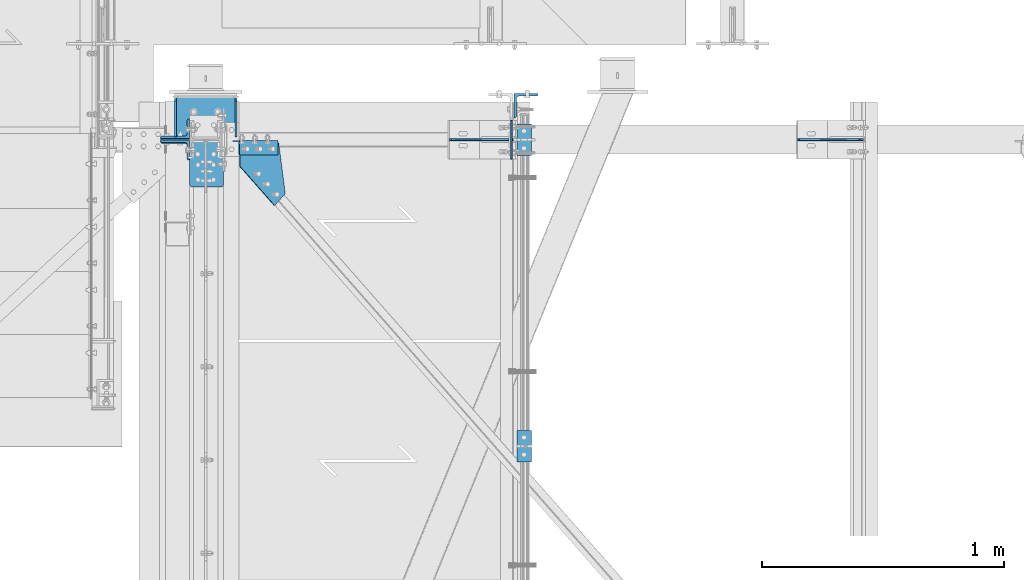
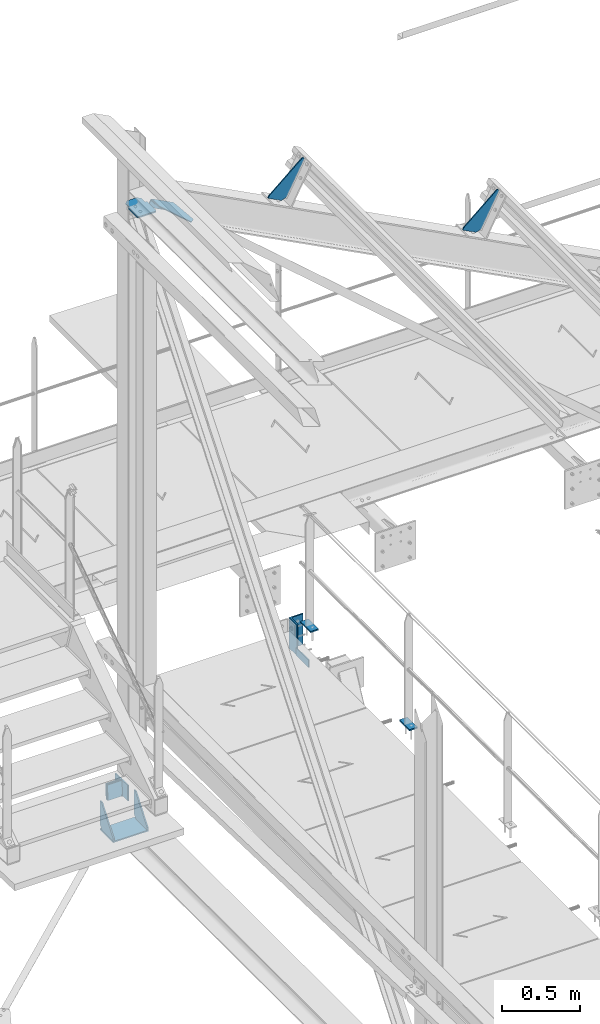
# One storey, part 83 of 496: 11 beams, 3 members, 11 elements without a shape of their own.
"""IFC2X3 building model written with IfcOpenShell, lengths in millimetres."""

import ifcopenshell
import ifcopenshell.guid

model = None  # the IFC model being written
_history = None  # IfcOwnerHistory: only IFC2X3 demands one
_inside = {}  # id of a spatial element -> (the spatial element, [elements in it])
_under = {}  # id of a project, library or spatial element -> (it, [spatial elements below it])
_declared = {}  # id of a project -> (the project, [libraries it declares])
_typed = {}  # id of a type object -> (the type object, [elements of that type])
_made_of = {}  # id of a material, layer set ... -> (it, [elements and type objects made of it])


def new_model(schema):
    """Start an empty IFC model of exactly this schema.

    Asked for "IFC4X3", IfcOpenShell would pick the latest addendum, in which some entities
    have other attributes; the version numbers below select the first issue.
    IFC2X3 requires an IfcOwnerHistory on every rooted entity: one is made here for all.
    """
    global model, _history
    if schema == "IFC4X3":
        model = ifcopenshell.file(schema_version=(4, 3, 0, 0))
    else:
        model = ifcopenshell.file(schema=schema)
    _inside.clear()
    _under.clear()
    _declared.clear()
    _typed.clear()
    _made_of.clear()
    _history = None
    if model.schema == "IFC2X3":
        org = make("IfcOrganization", Name="unknown")
        user = make(
            "IfcPersonAndOrganization",
            ThePerson=make("IfcPerson", FamilyName="unknown"),
            TheOrganization=org,
        )
        app = make(
            "IfcApplication",
            ApplicationDeveloper=org,
            Version="unknown",
            ApplicationFullName="unknown",
            ApplicationIdentifier="unknown",
        )
        _history = make(
            "IfcOwnerHistory",
            OwningUser=user,
            OwningApplication=app,
            ChangeAction="ADDED",
            CreationDate=0,
        )
    return model


def make(cls, **values):
    """One entity of the class cls with the attributes given. An attribute that is None is left unset."""
    return model.create_entity(
        cls, **{name: value for name, value in values.items() if value is not None}
    )


def rooted(cls, **values):
    """An entity with a GlobalId (a new one), such as an element, a storey or a relation."""
    return make(cls, GlobalId=ifcopenshell.guid.new(), OwnerHistory=_history, **values)


def si_unit(unit_type, name, prefix=None):
    """IfcSIUnit, for example si_unit("LENGTHUNIT", "METRE", prefix="MILLI")."""
    return make("IfcSIUnit", UnitType=unit_type, Prefix=prefix, Name=name)


def assignment(units):
    """IfcUnitAssignment: the units of a project."""
    return None if units is None else make("IfcUnitAssignment", Units=units)


def point(xyz):
    """IfcCartesianPoint."""
    return None if xyz is None else make("IfcCartesianPoint", Coordinates=xyz)


def direction(xyz):
    """IfcDirection."""
    return None if xyz is None else make("IfcDirection", DirectionRatios=xyz)


def frame(location, z_axis=None, x_axis=None):
    """IfcAxis2Placement3D, a coordinate frame: its origin and axes. An axis left out is left unset."""
    return make(
        "IfcAxis2Placement3D",
        Location=point(location),
        Axis=direction(z_axis),
        RefDirection=direction(x_axis),
    )


def frame_2d(location, x_axis=None):
    """IfcAxis2Placement2D, a coordinate frame in the plane: its origin and x axis."""
    return make(
        "IfcAxis2Placement2D", Location=point(location), RefDirection=direction(x_axis)
    )


def origin_with_axes():
    """The frame at (0, 0, 0) with the z axis (0, 0, 1) and the x axis (1, 0, 0) written out."""
    return frame((0.0, 0.0, 0.0), z_axis=(0.0, 0.0, 1.0), x_axis=(1.0, 0.0, 0.0))


def origin_2d_with_axis():
    """The frame at (0, 0) in the plane with the x axis (1, 0) written out."""
    return frame_2d((0.0, 0.0), x_axis=(1.0, 0.0))


def place(relative_to, where):
    """IfcLocalPlacement: puts the frame where relative to a parent placement (None: the world)."""
    return make(
        "IfcLocalPlacement", PlacementRelTo=relative_to, RelativePlacement=where
    )


def context(
    kind, dimensions, precision=None, world=None, true_north=None, identifier=None
):
    """IfcGeometricRepresentationContext, for example the 3D "Model" context."""
    return make(
        "IfcGeometricRepresentationContext",
        ContextIdentifier=identifier,
        ContextType=kind,
        CoordinateSpaceDimension=dimensions,
        Precision=precision,
        WorldCoordinateSystem=world,
        TrueNorth=true_north,
    )


def subcontext(parent, identifier, kind, view, scale=None):
    """IfcGeometricRepresentationSubContext, for example "Body" below "Model"."""
    return make(
        "IfcGeometricRepresentationSubContext",
        ContextIdentifier=identifier,
        ContextType=kind,
        ParentContext=parent,
        TargetScale=scale,
        TargetView=view,
    )


def project(units=None, contexts=None):
    """IfcProject with its units and contexts."""
    return rooted(
        "IfcProject",
        Name="project",
        RepresentationContexts=contexts,
        UnitsInContext=assignment(units),
    )


def spatial(cls, under=None, at=None, **own):
    """A site, building, storey or space (cls), placed at a placement, below another one or the project."""
    s = rooted(cls, ObjectPlacement=at, **own)
    if under is not None:
        _under.setdefault(under.id(), (under, []))[1].append(s)
    return s


def polyline(points):
    """IfcPolyline through the points."""
    return make("IfcPolyline", Points=[point(p) for p in points])


def circle_curve(where, radius):
    """IfcCircle in the frame where."""
    return make("IfcCircle", Position=where, Radius=radius)


def parameter(value):
    """IfcParameterValue: where a trimmed curve begins or ends, as a parameter of its basis curve."""
    return model.create_entity("IfcParameterValue", value)


def trimmed(basis, trim1, trim2, sense, master):
    """IfcTrimmedCurve: the piece of a basis curve between two trims."""
    return make(
        "IfcTrimmedCurve",
        BasisCurve=basis,
        Trim1=trim1,
        Trim2=trim2,
        SenseAgreement=sense,
        MasterRepresentation=master,
    )


def segment(curve, same_sense, transition):
    """IfcCompositeCurveSegment."""
    return make(
        "IfcCompositeCurveSegment",
        Transition=transition,
        SameSense=same_sense,
        ParentCurve=curve,
    )


def composite_curve(segments, self_intersect=None):
    """IfcCompositeCurve: segments joined end to end."""
    return make("IfcCompositeCurve", Segments=segments, SelfIntersect=self_intersect)


def profile(cls, at=None, kind="AREA", **sizes):
    """A parametric profile (cls). Its sizes go by their IFC names, for example OverallWidth=200.0."""
    return make(cls, ProfileType=kind, Position=at, **sizes)


def rectangle(**sizes):
    """IfcRectangleProfileDef."""
    return profile("IfcRectangleProfileDef", **sizes)


def l_section(**sizes):
    """IfcLShapeProfileDef."""
    return profile("IfcLShapeProfileDef", **sizes)


def outline(outer, holes=None, kind="AREA"):
    """IfcArbitraryClosedProfileDef: a profile drawn as a closed curve; with holes, ...WithVoids."""
    if holes is None:
        return make("IfcArbitraryClosedProfileDef", ProfileType=kind, OuterCurve=outer)
    return make(
        "IfcArbitraryProfileDefWithVoids",
        ProfileType=kind,
        OuterCurve=outer,
        InnerCurves=holes,
    )


def extrude(swept, where, along, depth):
    """IfcExtrudedAreaSolid: the profile swept, set in the frame where, extruded along a direction by depth."""
    return make(
        "IfcExtrudedAreaSolid",
        SweptArea=swept,
        Position=where,
        ExtrudedDirection=direction(along),
        Depth=depth,
    )


def shape(context_of_items, identifier, shape_type, items):
    """IfcShapeRepresentation: the items that make up one representation, for example the "Body"."""
    return make(
        "IfcShapeRepresentation",
        ContextOfItems=context_of_items,
        RepresentationIdentifier=identifier,
        RepresentationType=shape_type,
        Items=items,
    )


def material(Name=None, Category=None):
    """IfcMaterial."""
    return make("IfcMaterial", Name=Name, Category=Category)


def made_of(thing, what):
    """Note that an element or type object is made of a material, layer set ...; save() writes the relation."""
    if what is not None:
        _made_of.setdefault(what.id(), (what, []))[1].append(thing)
    return thing


def type_object(cls, material=None, **own):
    """A type object (cls), such as IfcWallType, which elements share."""
    return made_of(rooted(cls, **own), material)


def element(
    cls,
    number,
    at=None,
    inside=None,
    cuts=None,
    type_object=None,
    material=None,
    context=None,
    identifier="Body",
    shape_type=None,
    held_by="IfcProductDefinitionShape",
    body=None,
    shapes=None,
    **own,
):
    """One element of the class cls, such as IfcWall. Its Tag is "e" and its number.

    at: its placement. inside: the storey or other place that contains it. cuts: it is an
    opening in that element (IfcRelVoidsElement). A single representation is given by context,
    identifier, shape_type and body (its items); several are given by shapes. held_by: the class
    of the entity that holds the representations. save() writes the other relations.
    """
    e = rooted(cls, Tag="e%d" % number, ObjectPlacement=at, **own)
    if body is not None:
        shapes = [shape(context, identifier, shape_type, body)]
    if shapes is not None:
        e.Representation = make(held_by, Representations=shapes)
    if inside is not None:
        _inside.setdefault(inside.id(), (inside, []))[1].append(e)
    if cuts is not None:
        rooted(
            "IfcRelVoidsElement", RelatingBuildingElement=cuts, RelatedOpeningElement=e
        )
    if type_object is not None:
        _typed.setdefault(type_object.id(), (type_object, []))[1].append(e)
    return made_of(e, material)


def aggregate(whole, parts):
    """IfcRelAggregates: a whole, such as a stair, and the parts it consists of."""
    return rooted("IfcRelAggregates", RelatingObject=whole, RelatedObjects=parts)


def save(model, path):
    """Write the relations noted so far, then the file.

    IfcRelAggregates (storeys below a building ...), IfcRelContainedInSpatialStructure (elements
    in a storey), IfcRelDefinesByType, IfcRelAssociatesMaterial and IfcRelDeclares: one each for
    every whole, place, type object, material and project.
    """
    for whole, parts in _under.values():
        aggregate(whole, parts)
    for where, things in _inside.values():
        rooted(
            "IfcRelContainedInSpatialStructure",
            RelatedElements=things,
            RelatingStructure=where,
        )
    for kind, things in _typed.values():
        rooted("IfcRelDefinesByType", RelatedObjects=things, RelatingType=kind)
    for what, things in _made_of.values():
        rooted("IfcRelAssociatesMaterial", RelatedObjects=things, RelatingMaterial=what)
    for by, libraries in _declared.values():
        rooted("IfcRelDeclares", RelatingContext=by, RelatedDefinitions=libraries)
    model.write(path)


model = new_model("IFC2X3")

# Units and contexts
model_context = context("Model", 3, precision=1e-05, world=origin_with_axes())
body_context = subcontext(model_context, "Body", "Model", "MODEL_VIEW")
ifc_project = project(units=[si_unit("LENGTHUNIT", "METRE", prefix="MILLI"), si_unit("AREAUNIT", "SQUARE_METRE"), si_unit("VOLUMEUNIT", "CUBIC_METRE"), si_unit("MASSUNIT", "GRAM", prefix="KILO"), si_unit("TIMEUNIT", "SECOND"), si_unit("PLANEANGLEUNIT", "RADIAN"), si_unit("SOLIDANGLEUNIT", "STERADIAN"), si_unit("THERMODYNAMICTEMPERATUREUNIT", "DEGREE_CELSIUS"), si_unit("LUMINOUSINTENSITYUNIT", "LUMEN")], contexts=[model_context])

# Site, building, storey
site_placement = place(None, origin_with_axes())
site = spatial("IfcSite", under=ifc_project, at=site_placement, CompositionType="ELEMENT")
building_placement = place(site_placement, origin_with_axes())
building = spatial("IfcBuilding", under=site, at=building_placement, Name="Undefined", CompositionType="ELEMENT")
storey_placement = place(building_placement, origin_with_axes())
storey = spatial("IfcBuildingStorey", under=building, at=storey_placement, Name="Undefined", CompositionType="ELEMENT", Elevation=0.0)

# Assembly, beams
assembly_1_placement = place(storey_placement, origin_with_axes())
assembly_1 = element("IfcElementAssembly", 1, at=assembly_1_placement, inside=storey, Name="MAIN COURANTE", AssemblyPlace="NOTDEFINED", PredefinedType="NOTDEFINED")
ifc_material = material(Name="Undefined/S235-E24")
beam_type_1 = type_object("IfcBeamType", PredefinedType="NOTDEFINED")
beam_1_placement = place(assembly_1_placement, frame((13993.9998936979, 15265.0000000346, 8244.99999825262), z_axis=(-1.0, 0.0, 0.0), x_axis=(0.0, -1.0, 0.0)))
beam_1 = element("IfcBeam", 2, at=beam_1_placement, type_object=beam_type_1, material=ifc_material, context=body_context, shape_type="SweptSolid", body=[
    extrude(rectangle(XDim=10.0, YDim=60.0, at=origin_2d_with_axis()), frame((130.0, 0.0, 0.0), z_axis=(-1.0, 0.0, 0.0), x_axis=(0.0, -1.0, 0.0)), (0.0, 0.0, 1.0), 130.0),
])
beam_2_placement = place(assembly_1_placement, frame((13993.9998927259, 14000.0034471735, 8244.99999921369), z_axis=(-1.0, 0.0, 0.0), x_axis=(0.0, -1.0, 0.0)))
beam_2 = element("IfcBeam", 3, at=beam_2_placement, type_object=beam_type_1, material=ifc_material, context=body_context, shape_type="SweptSolid", body=[
    extrude(rectangle(XDim=10.0, YDim=60.0, at=origin_2d_with_axis()), frame((130.0, 0.0, 0.0), z_axis=(-1.0, 0.0, 0.0), x_axis=(0.0, -1.0, 0.0)), (0.0, 0.0, 1.0), 130.0),
])
aggregate(assembly_1, [beam_1, beam_2])

# Assembly, beam
assembly_2_placement = place(storey_placement, origin_with_axes())
assembly_2 = element("IfcElementAssembly", 4, at=assembly_2_placement, inside=storey, AssemblyPlace="NOTDEFINED", PredefinedType="NOTDEFINED")
beam_type_2 = type_object("IfcBeamType", PredefinedType="NOTDEFINED")
beam_3_placement = place(assembly_2_placement, frame((13007.0676558172, 14977.2888843132, 11896.7090467661), z_axis=(0.46352885499701, 6.99999093634976e-09, 0.886081824994261), x_axis=(-0.128579949951166, 0.989415431624208, 0.0672629179744489)))
beam_3 = element("IfcBeam", 5, at=beam_3_placement, type_object=beam_type_2, material=ifc_material, context=body_context, shape_type="SweptSolid", body=[
    extrude(outline(polyline([(0.0, 0.0), (211.449417114012, -6.94853952154517e-10), (237.569351195976, 178.094726562912), (142.065780639216, 192.101562500548), (-41.6174392705907, 56.2848854063404), (0.0, 0.0)])), frame((0.0, 0.0, -3.0), z_axis=(0.0, 0.0, 1.0), x_axis=(1.0, 0.0, 0.0)), (0.0, 0.0, 1.0), 6.0),
])
aggregate(assembly_2, [beam_3])

# Assembly, member
assembly_3_placement = place(storey_placement, origin_with_axes())
assembly_3 = element("IfcElementAssembly", 6, at=assembly_3_placement, inside=storey, AssemblyPlace="NOTDEFINED", PredefinedType="NOTDEFINED")
member_type_1 = type_object("IfcMemberType", PredefinedType="NOTDEFINED")
member_1_placement = place(assembly_3_placement, frame((12805.0882876368, 15166.5001030461, 11965.1261729301), z_axis=(0.0, -1.0, 0.0), x_axis=(0.886081856298361, 3.500000375794e-08, -0.463528795156082)))
member_1 = element("IfcMember", 7, at=member_1_placement, type_object=member_type_1, material=ifc_material, context=body_context, shape_type="SweptSolid", body=[
    extrude(l_section(Depth=60.0, Width=60.0, Thickness=6.0, FilletRadius=8.0, EdgeRadius=4.0, at=origin_2d_with_axis()), frame((180.0, 0.0, 0.0), z_axis=(-1.0, 0.0, 0.0), x_axis=(0.0, -1.0, 0.0)), (0.0, 0.0, 1.0), 180.0),
])
aggregate(assembly_3, [member_1])

# Assembly, beam
assembly_4_placement = place(storey_placement, origin_with_axes())
assembly_4 = element("IfcElementAssembly", 8, at=assembly_4_placement, inside=storey, Name="SHED", AssemblyPlace="NOTDEFINED", PredefinedType="NOTDEFINED")
beam_type_3 = type_object("IfcBeamType", PredefinedType="NOTDEFINED")
beam_4_placement = place(assembly_4_placement, frame((15395.0613651869, 15200.0, 11158.7378432617), z_axis=(0.0, -1.0, 0.0), x_axis=(-0.886081824994261, -1.3000000762986e-08, 0.46352885499701)))
beam_4 = element("IfcBeam", 9, at=beam_4_placement, type_object=beam_type_3, material=ifc_material, context=body_context, shape_type="SweptSolid", body=[
    extrude(outline(polyline([(0.0, 0.0), (20.0, 0.0), (140.000030519084, 299.999999999567), (140.000030519153, 319.999999999545), (30.0000147075953, 319.999999999634), (0.0, 290.0), (0.0, 0.0)])), frame((0.0, 0.0, -4.0), z_axis=(0.0, 0.0, 1.0), x_axis=(1.0, 0.0, 0.0)), (0.0, 0.0, 1.0), 8.0),
])
aggregate(assembly_4, [beam_4])

assembly_5_placement = place(storey_placement, origin_with_axes())
assembly_5 = element("IfcElementAssembly", 10, at=assembly_5_placement, inside=storey, Name="SHED", AssemblyPlace="NOTDEFINED", PredefinedType="NOTDEFINED")
beam_5_placement = place(assembly_5_placement, frame((13957.7613225854, 15200.0, 11910.6201334583), z_axis=(0.0, -1.0, 0.0), x_axis=(-0.886081824994261, -1.3000000762986e-08, 0.46352885499701)))
beam_5 = element("IfcBeam", 11, at=beam_5_placement, type_object=beam_type_3, material=ifc_material, context=body_context, shape_type="SweptSolid", body=[
    extrude(outline(polyline([(0.0, 0.0), (20.0, 0.0), (140.000030519084, 299.999999999567), (140.000030519153, 319.999999999545), (30.0000147075953, 319.999999999634), (0.0, 290.0), (0.0, 0.0)])), frame((0.0, 0.0, -4.0), z_axis=(0.0, 0.0, 1.0), x_axis=(1.0, 0.0, 0.0)), (0.0, 0.0, 1.0), 8.0),
])
aggregate(assembly_5, [beam_5])

assembly_6_placement = place(storey_placement, origin_with_axes())
assembly_6 = element("IfcElementAssembly", 12, at=assembly_6_placement, inside=storey, AssemblyPlace="NOTDEFINED", PredefinedType="NOTDEFINED")
beam_type_4 = type_object("IfcBeamType", PredefinedType="NOTDEFINED")
beam_6_placement = place(assembly_6_placement, frame((13942.9998855295, 15120.0, 7985.0), z_axis=(-1.0, 0.0, 0.0), x_axis=(0.0, 0.0, 1.0)))
beam_6 = element("IfcBeam", 13, at=beam_6_placement, type_object=beam_type_4, material=ifc_material, context=body_context, shape_type="SweptSolid", body=[
    extrude(outline(polyline([(0.0, 0.0), (60.0, 0.0), (60.0, 159.999984741211), (0.0, 159.999984741211), (0.0, 0.0)])), frame((0.0, 0.0, -3.0), z_axis=(0.0, 0.0, 1.0), x_axis=(1.0, 0.0, 0.0)), (0.0, 0.0, 1.0), 6.0),
])
aggregate(assembly_6, [beam_6])

# Assembly, member
assembly_7_placement = place(storey_placement, origin_with_axes())
assembly_7 = element("IfcElementAssembly", 14, at=assembly_7_placement, inside=storey, AssemblyPlace="NOTDEFINED", PredefinedType="NOTDEFINED")
member_type_2 = type_object("IfcMemberType", PredefinedType="NOTDEFINED")
member_2_placement = place(assembly_7_placement, frame((12553.5000000005, 15244.8642482558, 7530.88751296382), z_axis=(-1.0, 0.0, 0.0), x_axis=(0.0, -0.031410887010906, -0.999506556345274)))
member_2 = element("IfcMember", 15, at=member_2_placement, type_object=member_type_2, material=ifc_material, context=body_context, shape_type="SweptSolid", body=[
    extrude(l_section(Depth=120.0, Width=80.0, Thickness=10.0, FilletRadius=11.0, EdgeRadius=5.5, at=origin_2d_with_axis()), frame((120.0, 0.0, 0.0), z_axis=(-1.0, 0.0, 0.0), x_axis=(0.0, -1.0, 0.0)), (0.0, 0.0, 1.0), 120.0),
])
aggregate(assembly_7, [member_2])

assembly_8_placement = place(storey_placement, origin_with_axes())
assembly_8 = element("IfcElementAssembly", 16, at=assembly_8_placement, inside=storey, AssemblyPlace="NOTDEFINED", PredefinedType="NOTDEFINED")
member_3_placement = place(assembly_8_placement, frame((12553.5000000006, 15155.1364772786, 7413.64811928758), z_axis=(-1.0, 0.0, 0.0), x_axis=(0.0, 0.031410887010906, 0.999506556345274)))
member_3 = element("IfcMember", 17, at=member_3_placement, type_object=member_type_2, material=ifc_material, context=body_context, shape_type="SweptSolid", body=[
    extrude(l_section(Depth=120.0, Width=80.0, Thickness=10.0, FilletRadius=11.0, EdgeRadius=5.5, at=origin_2d_with_axis()), frame((120.0, 0.0, 0.0), z_axis=(-1.0, 0.0, 0.0), x_axis=(0.0, -1.0, 0.0)), (0.0, 0.0, 1.0), 120.0),
])
aggregate(assembly_8, [member_3])

# Assembly, beam
assembly_9_placement = place(storey_placement, origin_with_axes())
assembly_9 = element("IfcElementAssembly", 18, at=assembly_9_placement, inside=storey, AssemblyPlace="NOTDEFINED", PredefinedType="NOTDEFINED")
beam_type_5 = type_object("IfcBeamType", PredefinedType="NOTDEFINED")
beam_7_placement = place(assembly_9_placement, frame((14002.4998855292, 15339.9999998736, 8210.00437164958), z_axis=(1.0, 0.0, 0.0), x_axis=(0.0, 0.0, -1.0)))
beam_7 = element("IfcBeam", 19, at=beam_7_placement, type_object=beam_type_5, material=ifc_material, context=body_context, shape_type="SweptSolid", body=[
    extrude(l_section(Depth=100.0, Width=100.0, Thickness=10.0, FilletRadius=12.0, EdgeRadius=6.0, at=origin_2d_with_axis()), frame((240.0, 0.0, 0.0), z_axis=(-1.0, 0.0, 0.0), x_axis=(0.0, -1.0, 0.0)), (0.0, 0.0, 1.0), 240.0),
])
aggregate(assembly_9, [beam_7])

assembly_10_placement = place(storey_placement, origin_with_axes())
assembly_10 = element("IfcElementAssembly", 20, at=assembly_10_placement, inside=storey, Name="MONTANT", AssemblyPlace="NOTDEFINED", PredefinedType="NOTDEFINED")
beam_type_6 = type_object("IfcBeamType", PredefinedType="NOTDEFINED")
beam_8_placement = place(assembly_10_placement, frame((12613.5, 15004.9969221117, 12032.0), z_axis=(0.0, 0.0, -1.0), x_axis=(0.0, 1.0, 0.0)))
beam_8 = element("IfcBeam", 21, at=beam_8_placement, type_object=beam_type_6, material=ifc_material, Name="PLAT", context=body_context, shape_type="SweptSolid", body=[
    extrude(outline(composite_curve([segment(trimmed(circle_curve(frame_2d((10.0, 10.0), x_axis=(-1.0, 0.0)), 10.0), [parameter(0.0)], [parameter(1.5707963267949)], True, "PARAMETER"), True, "CONTINUOUS"), segment(polyline([(9.99999999997453, 6.91215973347425e-11), (124.5, 0.0), (124.5, 9.0), (172.25, 9.0), (192.25, 29.0), (192.25, 104.0), (172.25, 124.0), (124.0, 124.0), (124.0, 140.0), (10.0, 140.0)]), True, "CONTINUOUS"), segment(trimmed(circle_curve(frame_2d((10.0, 130.0), x_axis=(0.0, 1.0)), 10.0), [parameter(0.0)], [parameter(1.5707963267949)], True, "PARAMETER"), True, "CONTINUOUS"), segment(polyline([(0.0, 130.0), (-1.81898940354586e-10, 10.0000000000073)]), True, "CONTINUOUS")], self_intersect=True)), frame((0.0, 0.0, -5.0), z_axis=(0.0, 0.0, 1.0), x_axis=(1.0, 0.0, 0.0)), (0.0, 0.0, 1.0), 10.0),
])
aggregate(assembly_10, [beam_8])

# Assembly, beams
assembly_11_placement = place(storey_placement, origin_with_axes())
assembly_11 = element("IfcElementAssembly", 22, at=assembly_11_placement, inside=storey, AssemblyPlace="NOTDEFINED", PredefinedType="NOTDEFINED")
beam_type_7 = type_object("IfcBeamType", PredefinedType="NOTDEFINED")
beam_9_placement = place(assembly_11_placement, frame((12679.9999999978, 15380.0000000968, 7055.0), z_axis=(-1.0, 0.0, 0.0), x_axis=(0.0, -1.0, 0.0)))
beam_9 = element("IfcBeam", 23, at=beam_9_placement, type_object=beam_type_7, material=ifc_material, context=body_context, shape_type="SweptSolid", body=[
    extrude(rectangle(XDim=10.0, YDim=260.0, at=origin_2d_with_axis()), frame((169.99999962021, 0.0, 0.0), z_axis=(-1.0, 0.0, 0.0), x_axis=(0.0, -1.0, 0.0)), (0.0, 0.0, 1.0), 170.0),
])
beam_type_8 = type_object("IfcBeamType", PredefinedType="NOTDEFINED")
beam_10_placement = place(assembly_11_placement, frame((12554.999999998, 15210.0000004596, 7060.0), z_axis=(-1.0, 0.0, 0.0), x_axis=(0.0, 0.0, 1.0)))
beam_10 = element("IfcBeam", 24, at=beam_10_placement, type_object=beam_type_8, material=ifc_material, context=body_context, shape_type="SweptSolid", body=[
    extrude(outline(polyline([(0.0, 0.0), (20.0, 0.0), (214.999206543105, 150.000000000417), (214.999145507967, 170.000000000417), (29.9999970386934, 170.00000000006), (-2.43872305231086e-06, 140.000000000005), (0.0, 0.0)])), frame((0.0, 0.0, -5.0), z_axis=(0.0, 0.0, 1.0), x_axis=(1.0, 0.0, 0.0)), (0.0, 0.0, 1.0), 10.0),
])
beam_11_placement = place(assembly_11_placement, frame((12804.9999999897, 15210.0000004648, 7060.00000000002), z_axis=(-1.0, 0.0, 0.0), x_axis=(0.0, 0.0, 1.0)))
beam_11 = element("IfcBeam", 25, at=beam_11_placement, type_object=beam_type_8, material=ifc_material, context=body_context, shape_type="SweptSolid", body=[
    extrude(outline(polyline([(0.0, 0.0), (20.0, 0.0), (214.999206543105, 150.000000000417), (214.999145507967, 170.000000000417), (29.9999970386934, 170.00000000006), (-2.43872305231086e-06, 140.000000000005), (0.0, 0.0)])), frame((0.0, 0.0, -5.0), z_axis=(0.0, 0.0, 1.0), x_axis=(1.0, 0.0, 0.0)), (0.0, 0.0, 1.0), 10.0),
])
aggregate(assembly_11, [beam_10, beam_11, beam_9])

save(model, "model.ifc")
